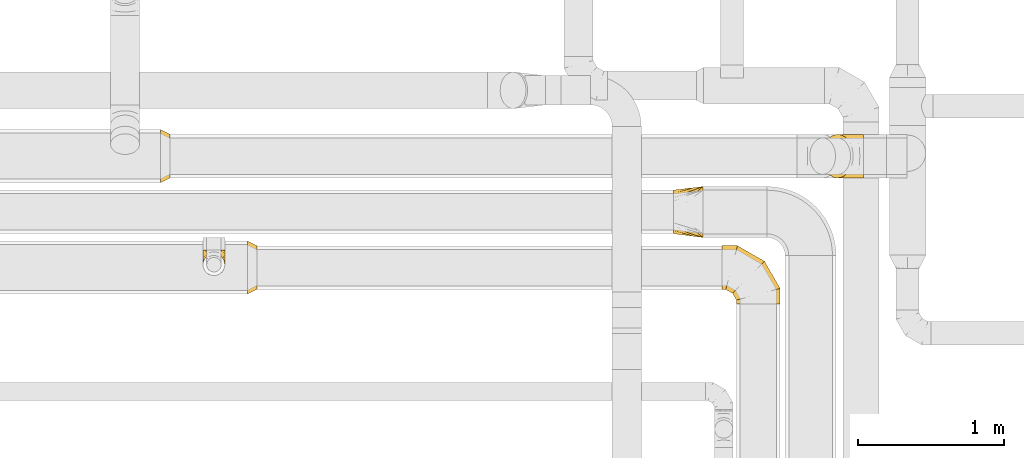
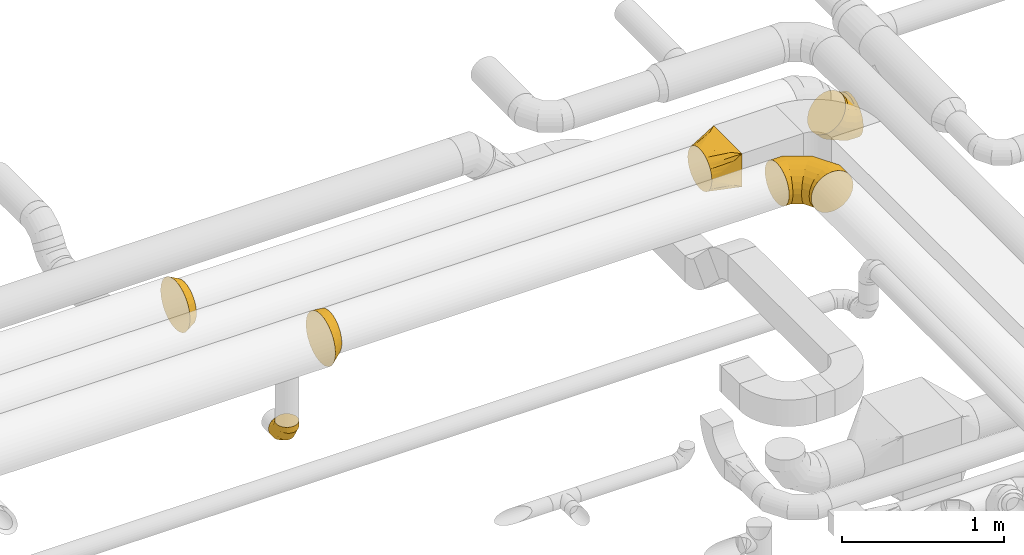
# One storey, part 25 of 92: 6 coverings.
"""IFC2X3 building model written with IfcOpenShell, lengths in millimetres."""

from ifc_helpers import new_model, entity, si_unit, converted_unit, derived_unit, direction, frame, origin, place, context, subcontext, project, spatial, faceted_brep, element, save


model = new_model("IFC2X3")

# Units and contexts
model_context = context("Model", 3, precision=0.01, world=origin(), true_north=direction((6.12303176911189e-17, 1.0)))
body_context = subcontext(model_context, "Body", "Model", "MODEL_VIEW")
ifc_project = project(units=[si_unit("LENGTHUNIT", "METRE", prefix="MILLI"), si_unit("AREAUNIT", "SQUARE_METRE"), si_unit("VOLUMEUNIT", "CUBIC_METRE"), converted_unit("PLANEANGLEUNIT", "DEGREE", entity("IfcRatioMeasure", 0.0174532925199433), si_unit("PLANEANGLEUNIT", "RADIAN"), dimensions=[0, 0, 0, 0, 0, 0, 0]), si_unit("MASSUNIT", "GRAM", prefix="KILO"), derived_unit("MASSDENSITYUNIT", [(si_unit("MASSUNIT", "GRAM", prefix="KILO"), 1), (si_unit("LENGTHUNIT", "METRE"), -3)]), derived_unit("MOMENTOFINERTIAUNIT", [(si_unit("LENGTHUNIT", "METRE"), 4)]), si_unit("TIMEUNIT", "SECOND"), si_unit("FREQUENCYUNIT", "HERTZ"), si_unit("THERMODYNAMICTEMPERATUREUNIT", "DEGREE_CELSIUS"), derived_unit("THERMALTRANSMITTANCEUNIT", [(si_unit("MASSUNIT", "GRAM", prefix="KILO"), 1), (si_unit("THERMODYNAMICTEMPERATUREUNIT", "KELVIN"), -1), (si_unit("TIMEUNIT", "SECOND"), -3)]), derived_unit("VOLUMETRICFLOWRATEUNIT", [(si_unit("LENGTHUNIT", "METRE"), 3), (si_unit("TIMEUNIT", "SECOND"), -1)]), derived_unit("MASSFLOWRATEUNIT", [(si_unit("MASSUNIT", "GRAM", prefix="KILO"), 1), (si_unit("TIMEUNIT", "SECOND"), -1)]), derived_unit("ROTATIONALFREQUENCYUNIT", [(si_unit("TIMEUNIT", "SECOND"), -1)]), si_unit("ELECTRICCURRENTUNIT", "AMPERE"), si_unit("ELECTRICVOLTAGEUNIT", "VOLT"), si_unit("POWERUNIT", "WATT"), si_unit("FORCEUNIT", "NEWTON", prefix="KILO"), si_unit("ILLUMINANCEUNIT", "LUX"), si_unit("LUMINOUSFLUXUNIT", "LUMEN"), si_unit("LUMINOUSINTENSITYUNIT", "CANDELA"), derived_unit("USERDEFINED", [(si_unit("MASSUNIT", "GRAM", prefix="KILO"), -1), (si_unit("LENGTHUNIT", "METRE"), -2), (si_unit("TIMEUNIT", "SECOND"), 3), (si_unit("LUMINOUSFLUXUNIT", "LUMEN"), 1)]), derived_unit("LINEARVELOCITYUNIT", [(si_unit("LENGTHUNIT", "METRE"), 1), (si_unit("TIMEUNIT", "SECOND"), -1)]), si_unit("PRESSUREUNIT", "PASCAL"), derived_unit("USERDEFINED", [(si_unit("LENGTHUNIT", "METRE"), -2), (si_unit("MASSUNIT", "GRAM", prefix="KILO"), 1), (si_unit("TIMEUNIT", "SECOND"), -2)]), derived_unit("LINEARFORCEUNIT", [(si_unit("MASSUNIT", "GRAM", prefix="KILO"), 1), (si_unit("LENGTHUNIT", "METRE"), 1), (si_unit("TIMEUNIT", "SECOND"), -2), (si_unit("LENGTHUNIT", "METRE"), -1)]), derived_unit("PLANARFORCEUNIT", [(si_unit("MASSUNIT", "GRAM", prefix="KILO"), 1), (si_unit("LENGTHUNIT", "METRE"), 1), (si_unit("TIMEUNIT", "SECOND"), -2), (si_unit("LENGTHUNIT", "METRE"), -2)])], contexts=[model_context])

# Site, building, storey
site_placement = place(None, origin())
site = spatial("IfcSite", under=ifc_project, at=site_placement, CompositionType="ELEMENT")
building_placement = place(site_placement, origin())
building = spatial("IfcBuilding", under=site, at=building_placement, CompositionType="ELEMENT")
storey_placement = place(building_placement, frame((0.0, 0.0, 4200.0)))
storey = spatial("IfcBuildingStorey", under=building, at=storey_placement, CompositionType="ELEMENT", Elevation=4200.0)

# Coverings
covering_1_placement = place(storey_placement, frame((60504.33, 15163.51, 3123.4)))
element("IfcCovering", 1, at=covering_1_placement, inside=storey, PredefinedType="INSULATION", context=body_context, shape_type="Brep", body=[
    faceted_brep([(0.0, 58.01, 242.13), (0.0, 69.93, 257.66), (0.0, 85.46, 269.58), (0.0, 100.99, 281.5), (0.0, 119.08, 288.99), (0.0, 137.17, 296.48), (0.0, 149.39, 298.09), (0.0, 161.61, 299.7), (0.0, 175.99, 301.6), (0.0, 190.37, 299.7), (0.0, 202.59, 298.09), (0.0, 214.81, 296.48), (0.0, 232.9, 288.99), (0.0, 250.99, 281.5), (0.0, 266.52, 269.58), (0.0, 282.06, 257.66), (0.0, 293.98, 242.13), (0.0, 305.89, 226.6), (0.0, 313.39, 208.51), (0.0, 320.88, 190.42), (0.0, 322.49, 178.2), (0.0, 324.1, 165.97), (0.0, 325.99, 151.6), (0.0, 324.1, 137.22), (0.0, 322.49, 124.99), (0.0, 320.88, 112.77), (0.0, 313.39, 94.68), (0.0, 305.89, 76.6), (0.0, 293.98, 61.06), (0.0, 282.06, 45.53), (0.0, 266.52, 33.61), (0.0, 250.99, 21.69), (0.0, 232.9, 14.2), (0.0, 214.81, 6.71), (0.0, 202.59, 5.1), (0.0, 190.37, 3.49), (0.0, 175.99, 1.6), (0.0, 161.61, 3.49), (0.0, 149.39, 5.1), (0.0, 137.17, 6.71), (0.0, 119.08, 14.2), (0.0, 100.99, 21.69), (0.0, 85.46, 33.61), (0.0, 69.93, 45.53), (0.0, 58.01, 61.06), (0.0, 46.09, 76.6), (0.0, 38.59, 94.68), (0.0, 31.1, 112.77), (0.0, 29.49, 124.99), (0.0, 27.88, 137.22), (0.0, 25.99, 151.6), (0.0, 27.88, 165.97), (0.0, 29.49, 178.2), (0.0, 31.1, 190.42), (0.0, 38.59, 208.51), (0.0, 46.09, 226.6), (200.0, 0.0, 301.6), (200.0, 0.0, 51.6), (200.0, 350.0, 51.6), (200.0, 350.0, 301.6), (71.91, 112.71, 19.57), (95.89, 91.62, 25.57), (121.91, 68.71, 32.07), (100.0, 38.27, 45.45), (173.97, 22.9, 45.09), (147.94, 6.77, 77.62), (173.97, 3.38, 64.61), (121.91, 10.15, 90.64), (95.89, 13.53, 103.65), (71.91, 16.65, 115.64), (23.97, 154.9, 7.59), (47.94, 133.8, 13.58), (47.94, 19.76, 127.62), (23.97, 22.88, 139.61), (147.94, 45.81, 38.58), (173.97, 3.38, 282.07), (147.94, 6.77, 262.55), (121.91, 10.15, 243.03), (95.89, 13.53, 223.51), (71.91, 16.65, 205.53), (47.94, 19.76, 187.55), (23.97, 22.88, 169.57), (100.0, 31.85, 276.32), (147.94, 45.81, 301.6), (173.97, 22.9, 301.6), (121.91, 68.71, 301.6), (95.89, 91.62, 301.6), (71.91, 112.71, 301.6), (47.94, 133.8, 301.6), (23.97, 154.9, 301.6), (173.97, 327.35, 301.6), (147.94, 304.71, 301.6), (121.91, 282.06, 301.6), (95.89, 259.42, 301.6), (71.91, 238.56, 301.6), (47.94, 217.7, 301.6), (23.97, 196.85, 301.6), (100.0, 312.72, 282.74), (147.94, 343.75, 262.55), (173.97, 346.88, 282.07), (121.91, 340.63, 243.03), (95.89, 337.5, 223.51), (71.91, 334.62, 205.53), (47.94, 331.75, 187.55), (23.97, 328.87, 169.57), (173.97, 346.88, 64.61), (147.94, 343.75, 77.62), (121.91, 340.63, 90.64), (95.89, 337.5, 103.65), (71.91, 334.62, 115.64), (47.94, 331.75, 127.62), (23.97, 328.87, 139.61), (100.0, 319.14, 51.87), (147.94, 304.71, 38.58), (173.97, 327.35, 45.09), (121.91, 282.06, 32.07), (95.89, 259.42, 25.57), (71.91, 238.56, 19.57), (47.94, 217.7, 13.58), (23.97, 196.85, 7.59)], [[[0, 1, 2, 3, 4, 5, 6, 7, 8, 9, 10, 11, 12, 13, 14, 15, 16, 17, 18, 19, 20, 21, 22, 23, 24, 25, 26, 27, 28, 29, 30, 31, 32, 33, 34, 35, 36, 37, 38, 39, 40, 41, 42, 43, 44, 45, 46, 47, 48, 49, 50, 51, 52, 53, 54, 55]], [[56, 57, 58, 59]], [[60, 61, 62, 40]], [[63, 42, 64]], [[44, 43, 63]], [[39, 60, 40]], [[40, 62, 41]], [[65, 45, 44]], [[44, 63, 66]], [[46, 67, 68, 69]], [[70, 71, 60, 39, 38, 37, 36]], [[48, 47, 69, 72, 73, 50, 49]], [[46, 45, 67]], [[46, 69, 47]], [[45, 65, 67]], [[42, 74, 64]], [[42, 41, 74]], [[57, 63, 64]], [[42, 63, 43]], [[44, 66, 65]], [[63, 57, 66]], [[62, 74, 41]], [[57, 56, 75, 76, 77, 78, 79, 80, 81, 50, 73, 72, 69, 68, 67, 65, 66]], [[79, 78, 77, 54]], [[82, 0, 75]], [[2, 1, 82]], [[53, 79, 54]], [[54, 77, 55]], [[83, 3, 2]], [[2, 82, 84]], [[4, 85, 86, 87]], [[81, 80, 79, 53, 52, 51, 50]], [[6, 5, 87, 88, 89, 8, 7]], [[4, 3, 85]], [[4, 87, 5]], [[3, 83, 85]], [[0, 76, 75]], [[0, 55, 76]], [[56, 82, 75]], [[0, 82, 1]], [[2, 84, 83]], [[82, 56, 84]], [[77, 76, 55]], [[89, 88, 87, 86, 85, 83, 84, 56, 59, 90, 91, 92, 93, 94, 95, 96, 8]], [[94, 93, 92, 12]], [[97, 14, 90]], [[16, 15, 97]], [[11, 94, 12]], [[12, 92, 13]], [[98, 17, 16]], [[16, 97, 99]], [[18, 100, 101, 102]], [[96, 95, 94, 11, 10, 9, 8]], [[20, 19, 102, 103, 104, 22, 21]], [[18, 17, 100]], [[18, 102, 19]], [[17, 98, 100]], [[14, 91, 90]], [[14, 13, 91]], [[59, 97, 90]], [[14, 97, 15]], [[16, 99, 98]], [[97, 59, 99]], [[92, 91, 13]], [[104, 103, 102, 101, 100, 98, 99, 59, 58, 105, 106, 107, 108, 109, 110, 111, 22]], [[109, 108, 107, 26]], [[112, 28, 105]], [[30, 29, 112]], [[25, 109, 26]], [[26, 107, 27]], [[113, 31, 30]], [[30, 112, 114]], [[32, 115, 116, 117]], [[111, 110, 109, 25, 24, 23, 22]], [[34, 33, 117, 118, 119, 36, 35]], [[32, 31, 115]], [[32, 117, 33]], [[31, 113, 115]], [[28, 106, 105]], [[28, 27, 106]], [[58, 112, 105]], [[28, 112, 29]], [[30, 114, 113]], [[112, 58, 114]], [[107, 106, 27]], [[58, 57, 64, 74, 62, 61, 60, 71, 70, 36, 119, 118, 117, 116, 115, 113, 114]]]),
])
covering_2_placement = place(storey_placement, frame((61522.45, 15570.41, 2848.4)))
element("IfcCovering", 2, at=covering_2_placement, inside=storey, PredefinedType="INSULATION", context=body_context, shape_type="Brep", body=[
    faceted_brep([(284.44, 151.6, 301.6), (284.44, 112.77, 296.48), (284.44, 76.6, 281.5), (284.44, 45.53, 257.66), (284.44, 21.69, 226.6), (284.44, 6.71, 190.42), (284.44, 1.6, 151.6), (284.44, 6.71, 112.77), (284.44, 21.69, 76.6), (284.44, 45.53, 45.53), (284.44, 76.6, 21.69), (284.44, 112.77, 6.71), (284.44, 151.6, 1.6), (284.44, 190.42, 6.71), (284.44, 226.6, 21.69), (284.44, 257.66, 45.53), (284.44, 281.5, 76.6), (284.44, 296.48, 112.77), (284.44, 301.6, 151.6), (284.44, 296.48, 190.42), (284.44, 281.5, 226.6), (284.44, 257.66, 257.66), (284.44, 226.6, 281.5), (284.44, 190.42, 296.48), (15.81, 226.6, 132.96), (5.21, 190.42, 122.37), (1.6, 151.6, 118.75), (5.21, 112.77, 122.37), (15.81, 76.6, 132.96), (32.66, 45.53, 149.82), (54.63, 21.69, 171.79), (80.21, 6.71, 197.37), (107.66, 1.6, 224.82), (135.11, 6.71, 252.27), (160.69, 21.69, 277.85), (182.66, 45.53, 299.82), (199.52, 76.6, 316.67), (210.11, 112.77, 327.27), (213.73, 151.6, 330.88), (210.11, 190.42, 327.27), (199.52, 226.6, 316.67), (182.66, 257.66, 299.82), (160.69, 281.5, 277.85), (135.11, 296.48, 252.27), (107.66, 301.6, 224.82), (80.21, 296.48, 197.37), (54.63, 281.5, 171.79), (32.66, 257.66, 149.82), (57.86, 151.6, 62.49), (60.75, 112.77, 66.82), (69.24, 76.6, 79.53), (82.74, 45.53, 99.74), (100.34, 21.69, 126.07), (120.83, 6.71, 156.74), (142.82, 1.6, 189.66), (164.82, 6.71, 222.57), (185.31, 21.69, 253.24), (202.91, 45.53, 279.57), (216.41, 76.6, 299.78), (224.9, 112.77, 312.49), (227.79, 151.6, 316.82), (224.9, 190.42, 312.49), (216.41, 226.6, 299.78), (202.91, 257.66, 279.57), (164.82, 296.48, 222.57), (142.82, 301.6, 189.66), (185.31, 281.5, 253.24), (120.83, 296.48, 156.74), (100.34, 281.5, 126.07), (82.74, 257.66, 99.74), (69.24, 226.6, 79.53), (60.75, 190.42, 66.82), (204.87, 151.6, 1.6), (205.89, 112.77, 6.71), (208.87, 76.6, 21.69), (213.61, 45.53, 45.53), (219.79, 21.69, 76.6), (226.99, 6.71, 112.77), (234.71, 1.6, 151.6), (242.43, 6.71, 190.42), (249.63, 21.69, 226.6), (255.81, 45.53, 257.66), (260.55, 76.6, 281.5), (263.53, 112.77, 296.48), (264.55, 151.6, 301.6), (263.53, 190.42, 296.48), (260.55, 226.6, 281.5), (255.81, 257.66, 257.66), (242.43, 296.48, 190.42), (234.71, 301.6, 151.6), (249.63, 281.5, 226.6), (226.99, 296.48, 112.77), (219.79, 281.5, 76.6), (213.61, 257.66, 45.53), (208.87, 226.6, 21.69), (205.89, 190.42, 6.71)], [[[0, 1, 2, 3, 4, 5, 6, 7, 8, 9, 10, 11, 12, 13, 14, 15, 16, 17, 18, 19, 20, 21, 22, 23]], [[24, 25, 26, 27, 28, 29, 30, 31, 32, 33, 34, 35, 36, 37, 38, 39, 40, 41, 42, 43, 44, 45, 46, 47]], [[26, 48, 49, 27]], [[27, 49, 50, 28]], [[51, 29, 28, 50]], [[29, 51, 52, 30]], [[30, 52, 53, 31]], [[54, 32, 31, 53]], [[55, 56, 34, 33]], [[54, 55, 33, 32]], [[57, 35, 34, 56]], [[58, 59, 37, 36]], [[58, 36, 35, 57]], [[60, 38, 37, 59]], [[61, 62, 40, 39]], [[60, 61, 39, 38]], [[41, 40, 62, 63]], [[64, 65, 44, 43]], [[66, 64, 43, 42]], [[63, 66, 42, 41]], [[45, 44, 65, 67]], [[46, 45, 67, 68]], [[47, 46, 68, 69]], [[25, 24, 70, 71]], [[26, 25, 71, 48]], [[69, 70, 24, 47]], [[49, 48, 72, 73]], [[50, 49, 73, 74]], [[74, 75, 51, 50]], [[52, 51, 75, 76]], [[53, 52, 76, 77]], [[54, 53, 77, 78]], [[79, 80, 56, 55]], [[78, 79, 55, 54]], [[57, 56, 80, 81]], [[82, 83, 59, 58]], [[81, 82, 58, 57]], [[60, 59, 83, 84]], [[85, 86, 62, 61]], [[84, 85, 61, 60]], [[63, 62, 86, 87]], [[88, 89, 65, 64]], [[90, 88, 64, 66]], [[87, 90, 66, 63]], [[67, 65, 89, 91]], [[68, 67, 91, 92]], [[69, 68, 92, 93]], [[71, 70, 94, 95]], [[48, 71, 95, 72]], [[93, 94, 70, 69]], [[73, 72, 12, 11]], [[74, 73, 11, 10]], [[10, 9, 75, 74]], [[77, 76, 8, 7]], [[78, 77, 7, 6]], [[9, 8, 76, 75]], [[79, 78, 6, 5]], [[80, 79, 5, 4]], [[81, 80, 4, 3]], [[83, 82, 2, 1]], [[84, 83, 1, 0]], [[81, 3, 2, 82]], [[84, 0, 23, 85]], [[85, 23, 22, 86]], [[86, 22, 21, 87]], [[90, 20, 19, 88]], [[88, 19, 18, 89]], [[90, 87, 21, 20]], [[17, 16, 92, 91]], [[18, 17, 91, 89]], [[15, 93, 92, 16]], [[94, 14, 13, 95]], [[95, 13, 12, 72]], [[14, 94, 93, 15]]]),
])
covering_3_placement = place(storey_placement, frame((56980.65, 15537.91, 3065.9)))
element("IfcCovering", 3, at=covering_3_placement, inside=storey, PredefinedType="INSULATION", context=body_context, shape_type="Brep", body=[
    faceted_brep([(0.0, 275.35, 342.14), (0.0, 313.14, 313.14), (0.0, 342.14, 275.35), (0.0, 360.38, 231.33), (0.0, 366.6, 184.1), (0.0, 360.38, 136.86), (0.0, 342.14, 92.85), (0.0, 313.14, 55.05), (0.0, 275.35, 26.05), (0.0, 231.33, 7.81), (0.0, 184.1, 1.6), (0.0, 136.86, 7.81), (0.0, 92.85, 26.05), (0.0, 55.05, 55.05), (0.0, 26.05, 92.85), (0.0, 7.81, 136.86), (0.0, 1.6, 184.1), (0.0, 7.81, 231.33), (0.0, 26.05, 275.35), (0.0, 55.05, 313.14), (0.0, 92.85, 342.14), (0.0, 136.86, 360.38), (0.0, 184.1, 366.6), (0.0, 231.33, 360.38), (65.0, 222.92, 328.98), (65.0, 184.1, 334.1), (65.0, 145.27, 328.98), (65.0, 109.1, 314.0), (65.0, 78.03, 290.16), (65.0, 54.19, 259.1), (65.0, 39.21, 222.92), (65.0, 34.1, 184.1), (65.0, 39.21, 145.27), (65.0, 54.19, 109.1), (65.0, 78.03, 78.03), (65.0, 109.1, 54.19), (65.0, 145.27, 39.21), (65.0, 184.1, 34.1), (65.0, 222.92, 39.21), (65.0, 259.1, 54.19), (65.0, 290.16, 78.03), (65.0, 314.0, 109.1), (65.0, 328.98, 145.27), (65.0, 334.1, 184.1), (65.0, 328.98, 222.92), (65.0, 314.0, 259.1), (65.0, 290.16, 290.16), (65.0, 259.1, 314.0)], [[[0, 1, 2, 3, 4, 5, 6, 7, 8, 9, 10, 11, 12, 13, 14, 15, 16, 17, 18, 19, 20, 21, 22, 23]], [[24, 25, 26, 27, 28, 29, 30, 31, 32, 33, 34, 35, 36, 37, 38, 39, 40, 41, 42, 43, 44, 45, 46, 47]], [[42, 41, 6, 5]], [[43, 42, 5, 4]], [[7, 6, 41, 40]], [[7, 40, 39, 8]], [[8, 39, 38, 9]], [[37, 10, 9, 38]], [[36, 35, 12, 11]], [[37, 36, 11, 10]], [[13, 12, 35, 34]], [[13, 34, 33, 14]], [[14, 33, 32, 15]], [[31, 16, 15, 32]], [[30, 29, 18, 17]], [[31, 30, 17, 16]], [[19, 18, 29, 28]], [[19, 28, 27, 20]], [[20, 27, 26, 21]], [[25, 22, 21, 26]], [[24, 47, 0, 23]], [[25, 24, 23, 22]], [[1, 0, 47, 46]], [[1, 46, 45, 2]], [[2, 45, 44, 3]], [[43, 4, 3, 44]]]),
])
covering_4_placement = place(storey_placement, frame((57270.37, 14900.4, 2523.4)))
element("IfcCovering", 4, at=covering_4_placement, inside=storey, PredefinedType="INSULATION", context=body_context, shape_type="Brep", body=[
    faceted_brep([(105.3, 176.6, 7.3), (90.95, 176.6, 4.45), (76.6, 176.6, 1.6), (62.24, 176.6, 4.45), (47.89, 176.6, 7.3), (35.73, 176.6, 15.43), (23.56, 176.6, 23.56), (15.43, 176.6, 35.73), (7.3, 176.6, 47.89), (4.45, 176.6, 62.24), (1.6, 176.6, 76.6), (4.45, 176.6, 90.95), (7.3, 176.6, 105.3), (15.43, 176.6, 117.46), (23.56, 176.6, 129.63), (35.73, 176.6, 137.76), (47.89, 176.6, 145.89), (62.24, 176.6, 148.74), (69.42, 176.6, 150.17), (76.6, 176.6, 151.6), (83.77, 176.6, 150.17), (90.95, 176.6, 148.74), (105.3, 176.6, 145.89), (117.46, 176.6, 137.76), (129.63, 176.6, 129.63), (137.76, 176.6, 117.46), (145.89, 176.6, 105.3), (148.74, 176.6, 90.95), (151.6, 176.6, 76.6), (148.74, 176.6, 62.24), (145.89, 176.6, 47.89), (137.76, 176.6, 35.73), (129.63, 176.6, 23.56), (117.46, 176.6, 15.43), (57.18, 4.15, 176.6), (76.6, 1.6, 176.6), (96.01, 4.15, 176.6), (114.1, 11.64, 176.6), (129.63, 23.56, 176.6), (141.55, 39.1, 176.6), (149.04, 57.18, 176.6), (151.6, 76.6, 176.6), (149.04, 96.01, 176.6), (141.55, 114.1, 176.6), (129.63, 129.63, 176.6), (114.1, 141.55, 176.6), (96.01, 149.04, 176.6), (76.6, 151.6, 176.6), (57.18, 149.04, 176.6), (39.1, 141.55, 176.6), (23.56, 129.63, 176.6), (11.64, 114.1, 176.6), (4.15, 96.01, 176.6), (1.6, 76.6, 176.6), (4.15, 57.18, 176.6), (11.64, 39.1, 176.6), (23.56, 23.56, 176.6), (39.1, 11.64, 176.6), (76.6, 1.6, 129.7), (96.01, 4.15, 130.39), (114.1, 11.64, 132.4), (129.63, 23.56, 135.59), (141.55, 39.1, 139.75), (149.04, 57.18, 144.6), (151.6, 76.6, 149.8), (149.04, 96.01, 155.0), (141.55, 114.1, 159.85), (129.63, 129.63, 164.01), (114.1, 141.55, 167.2), (96.01, 149.04, 169.21), (76.6, 151.6, 169.9), (57.18, 149.04, 169.21), (39.1, 141.55, 167.2), (23.56, 129.63, 164.01), (4.15, 96.01, 155.0), (1.6, 76.6, 149.8), (11.64, 114.1, 159.85), (4.15, 57.18, 144.6), (11.64, 39.1, 139.75), (23.56, 23.56, 135.59), (39.1, 11.64, 132.4), (57.18, 4.15, 130.39), (76.6, 48.49, 48.49), (96.01, 50.36, 50.36), (114.1, 55.84, 55.84), (129.63, 64.57, 64.57), (141.55, 75.94, 75.94), (149.04, 89.18, 89.18), (151.6, 103.39, 103.39), (149.04, 117.6, 117.6), (141.55, 130.84, 130.84), (129.63, 142.21, 142.21), (114.1, 150.94, 150.94), (96.01, 156.42, 156.42), (76.6, 158.29, 158.29), (57.18, 156.42, 156.42), (39.1, 150.94, 150.94), (23.56, 142.21, 142.21), (4.15, 117.6, 117.6), (1.6, 103.39, 103.39), (11.64, 130.84, 130.84), (4.15, 89.18, 89.18), (11.64, 75.94, 75.94), (23.56, 64.57, 64.57), (39.1, 55.84, 55.84), (57.18, 50.36, 50.36), (76.6, 129.7, 1.6), (96.01, 130.39, 4.15), (114.1, 132.4, 11.64), (129.63, 135.59, 23.56), (141.55, 139.75, 39.1), (149.04, 144.6, 57.18), (151.6, 149.8, 76.6), (149.04, 155.0, 96.01), (141.55, 159.85, 114.1), (129.63, 164.01, 129.63), (114.1, 167.2, 141.55), (105.05, 168.21, 145.29), (96.01, 169.21, 149.04), (86.3, 169.55, 150.32), (76.6, 169.9, 151.6), (57.18, 169.21, 149.04), (48.14, 168.21, 145.29), (39.1, 167.2, 141.55), (66.89, 169.55, 150.32), (23.56, 164.01, 129.63), (4.15, 155.0, 96.01), (1.6, 149.8, 76.6), (11.64, 159.85, 114.1), (4.15, 144.6, 57.18), (11.64, 139.75, 39.1), (23.56, 135.59, 23.56), (39.1, 132.4, 11.64), (57.18, 130.39, 4.15)], [[[0, 1, 2, 3, 4, 5, 6, 7, 8, 9, 10, 11, 12, 13, 14, 15, 16, 17, 18, 19, 20, 21, 22, 23, 24, 25, 26, 27, 28, 29, 30, 31, 32, 33]], [[34, 35, 36, 37, 38, 39, 40, 41, 42, 43, 44, 45, 46, 47, 48, 49, 50, 51, 52, 53, 54, 55, 56, 57]], [[35, 58, 59, 36]], [[36, 59, 60, 37]], [[37, 60, 61, 38]], [[39, 62, 63, 40]], [[40, 63, 64, 41]], [[38, 61, 62, 39]], [[65, 66, 43, 42]], [[64, 65, 42, 41]], [[67, 44, 43, 66]], [[68, 69, 46, 45]], [[68, 45, 44, 67]], [[70, 47, 46, 69]], [[71, 72, 49, 48]], [[70, 71, 48, 47]], [[50, 49, 72, 73]], [[74, 75, 53, 52]], [[76, 74, 52, 51]], [[73, 76, 51, 50]], [[55, 54, 77, 78]], [[56, 55, 78, 79]], [[53, 75, 77, 54]], [[34, 57, 80, 81]], [[35, 34, 81, 58]], [[79, 80, 57, 56]], [[58, 82, 83, 59]], [[60, 59, 83, 84]], [[84, 85, 61, 60]], [[62, 61, 85, 86]], [[63, 62, 86, 87]], [[64, 63, 87, 88]], [[89, 90, 66, 65]], [[88, 89, 65, 64]], [[67, 66, 90, 91]], [[92, 93, 69, 68]], [[91, 92, 68, 67]], [[70, 69, 93, 94]], [[95, 96, 72, 71]], [[94, 95, 71, 70]], [[73, 72, 96, 97]], [[98, 99, 75, 74]], [[100, 98, 74, 76]], [[97, 100, 76, 73]], [[77, 75, 99, 101]], [[78, 77, 101, 102]], [[79, 78, 102, 103]], [[81, 80, 104, 105]], [[58, 81, 105, 82]], [[103, 104, 80, 79]], [[82, 106, 107, 83]], [[84, 83, 107, 108]], [[108, 109, 85, 84]], [[86, 85, 109, 110]], [[87, 86, 110, 111]], [[88, 87, 111, 112]], [[113, 114, 90, 89]], [[112, 113, 89, 88]], [[91, 90, 114, 115]], [[93, 92, 116, 117, 118]], [[115, 116, 92, 91]], [[94, 93, 118, 119, 120]], [[95, 121, 122, 123, 96]], [[94, 120, 124, 121, 95]], [[97, 96, 123, 125]], [[126, 127, 99, 98]], [[128, 126, 98, 100]], [[125, 128, 100, 97]], [[101, 99, 127, 129]], [[102, 101, 129, 130]], [[103, 102, 130, 131]], [[105, 104, 132, 133]], [[82, 105, 133, 106]], [[131, 132, 104, 103]], [[106, 1, 107]], [[111, 30, 29]], [[1, 106, 2]], [[32, 109, 33]], [[108, 0, 33]], [[107, 0, 108]], [[31, 30, 110]], [[108, 33, 109]], [[31, 109, 32]], [[28, 112, 29]], [[1, 0, 107]], [[112, 111, 29]], [[110, 30, 111]], [[109, 31, 110]], [[113, 28, 27, 26]], [[24, 115, 25]], [[119, 21, 20]], [[114, 26, 25]], [[114, 113, 26]], [[120, 20, 19]], [[114, 25, 115]], [[28, 113, 112]], [[120, 119, 20]], [[21, 119, 118]], [[22, 118, 117, 116]], [[24, 23, 115]], [[115, 23, 116]], [[118, 22, 21]], [[116, 23, 22]], [[121, 17, 16]], [[15, 14, 125]], [[16, 123, 122, 121]], [[18, 17, 124]], [[18, 120, 19]], [[125, 123, 15]], [[13, 125, 14]], [[126, 12, 11, 10]], [[125, 13, 128]], [[120, 18, 124]], [[126, 128, 12]], [[126, 10, 127]], [[17, 121, 124]], [[123, 16, 15]], [[13, 12, 128]], [[127, 9, 129]], [[6, 131, 7]], [[130, 8, 7]], [[129, 8, 130]], [[5, 131, 6]], [[9, 8, 129]], [[130, 7, 131]], [[9, 127, 10]], [[133, 4, 3]], [[131, 5, 132]], [[2, 106, 3]], [[4, 133, 132]], [[106, 133, 3]], [[5, 4, 132]]]),
])
covering_5_placement = place(storey_placement, frame((60835.0, 14707.0, 3130.9)))
element("IfcCovering", 5, at=covering_5_placement, inside=storey, PredefinedType="INSULATION", context=body_context, shape_type="Brep", body=[
    faceted_brep([(0.0, 356.07, 257.66), (0.0, 379.9, 226.6), (0.0, 394.89, 190.42), (0.0, 400.0, 151.6), (0.0, 394.89, 112.77), (0.0, 379.9, 76.6), (0.0, 356.07, 45.53), (0.0, 325.0, 21.69), (0.0, 288.82, 6.71), (0.0, 250.0, 1.6), (0.0, 211.18, 6.71), (0.0, 175.0, 21.69), (0.0, 143.93, 45.53), (0.0, 120.1, 76.6), (0.0, 105.11, 112.77), (0.0, 100.0, 151.6), (0.0, 105.11, 190.42), (0.0, 120.1, 226.6), (0.0, 143.93, 257.66), (0.0, 175.0, 281.5), (0.0, 211.18, 296.48), (0.0, 250.0, 301.6), (0.0, 288.82, 296.48), (0.0, 325.0, 281.5), (379.9, 0.0, 76.6), (394.89, 0.0, 112.77), (400.0, 0.0, 151.6), (394.89, 0.0, 190.42), (379.9, 0.0, 226.6), (356.07, 0.0, 257.66), (325.0, 0.0, 281.5), (288.82, 0.0, 296.48), (250.0, 0.0, 301.6), (211.18, 0.0, 296.48), (175.0, 0.0, 281.5), (143.93, 0.0, 257.66), (120.1, 0.0, 226.6), (105.11, 0.0, 190.42), (100.0, 0.0, 151.6), (105.11, 0.0, 112.77), (120.1, 0.0, 76.6), (143.93, 0.0, 45.53), (175.0, 0.0, 21.69), (211.18, 0.0, 6.71), (250.0, 0.0, 1.6), (288.82, 0.0, 6.71), (325.0, 0.0, 21.69), (356.07, 0.0, 45.53), (400.0, 107.18, 151.6), (394.89, 105.81, 190.42), (379.9, 101.79, 226.6), (356.07, 95.41, 257.66), (325.0, 87.08, 281.5), (288.82, 77.39, 296.48), (250.0, 66.99, 301.6), (211.18, 56.58, 296.48), (175.0, 46.89, 281.5), (143.93, 38.57, 257.66), (120.1, 32.18, 226.6), (105.11, 28.16, 190.42), (100.0, 26.79, 151.6), (105.11, 28.16, 112.77), (120.1, 32.18, 76.6), (143.93, 38.57, 45.53), (211.18, 56.58, 6.71), (250.0, 66.99, 1.6), (175.0, 46.89, 21.69), (288.82, 77.39, 6.71), (325.0, 87.08, 21.69), (356.07, 95.41, 45.53), (379.9, 101.79, 76.6), (394.89, 105.81, 112.77), (292.82, 292.82, 151.6), (289.08, 289.08, 190.42), (278.11, 278.11, 226.6), (260.66, 260.66, 257.66), (237.92, 237.92, 281.5), (211.43, 211.43, 296.48), (183.01, 183.01, 301.6), (154.59, 154.59, 296.48), (128.11, 128.11, 281.5), (105.37, 105.37, 257.66), (87.92, 87.92, 226.6), (76.95, 76.95, 190.42), (73.21, 73.21, 151.6), (76.95, 76.95, 112.77), (87.92, 87.92, 76.6), (105.37, 105.37, 45.53), (154.59, 154.59, 6.71), (183.01, 183.01, 1.6), (128.11, 128.11, 21.69), (211.43, 211.43, 6.71), (237.92, 237.92, 21.69), (260.66, 260.66, 45.53), (278.11, 278.11, 76.6), (289.08, 289.08, 112.77), (107.18, 400.0, 151.6), (105.81, 394.89, 190.42), (101.79, 379.9, 226.6), (95.41, 356.07, 257.66), (87.08, 325.0, 281.5), (77.39, 288.82, 296.48), (66.99, 250.0, 301.6), (56.58, 211.18, 296.48), (46.89, 175.0, 281.5), (38.57, 143.93, 257.66), (32.18, 120.1, 226.6), (28.16, 105.11, 190.42), (26.79, 100.0, 151.6), (28.16, 105.11, 112.77), (32.18, 120.1, 76.6), (38.57, 143.93, 45.53), (56.58, 211.18, 6.71), (66.99, 250.0, 1.6), (46.89, 175.0, 21.69), (77.39, 288.82, 6.71), (87.08, 325.0, 21.69), (95.41, 356.07, 45.53), (101.79, 379.9, 76.6), (105.81, 394.89, 112.77)], [[[0, 1, 2, 3, 4, 5, 6, 7, 8, 9, 10, 11, 12, 13, 14, 15, 16, 17, 18, 19, 20, 21, 22, 23]], [[24, 25, 26, 27, 28, 29, 30, 31, 32, 33, 34, 35, 36, 37, 38, 39, 40, 41, 42, 43, 44, 45, 46, 47]], [[26, 48, 49, 27]], [[27, 49, 50, 28]], [[51, 29, 28, 50]], [[29, 51, 52, 30]], [[30, 52, 53, 31]], [[54, 32, 31, 53]], [[55, 56, 34, 33]], [[54, 55, 33, 32]], [[57, 35, 34, 56]], [[58, 59, 37, 36]], [[58, 36, 35, 57]], [[60, 38, 37, 59]], [[61, 62, 40, 39]], [[60, 61, 39, 38]], [[41, 40, 62, 63]], [[64, 65, 44, 43]], [[66, 64, 43, 42]], [[63, 66, 42, 41]], [[45, 44, 65, 67]], [[46, 45, 67, 68]], [[68, 69, 47, 46]], [[25, 24, 70, 71]], [[26, 25, 71, 48]], [[69, 70, 24, 47]], [[49, 48, 72, 73]], [[50, 49, 73, 74]], [[74, 75, 51, 50]], [[52, 51, 75, 76]], [[53, 52, 76, 77]], [[54, 53, 77, 78]], [[79, 80, 56, 55]], [[78, 79, 55, 54]], [[57, 56, 80, 81]], [[82, 83, 59, 58]], [[81, 82, 58, 57]], [[60, 59, 83, 84]], [[85, 86, 62, 61]], [[84, 85, 61, 60]], [[63, 62, 86, 87]], [[88, 89, 65, 64]], [[90, 88, 64, 66]], [[87, 90, 66, 63]], [[67, 65, 89, 91]], [[68, 67, 91, 92]], [[69, 68, 92, 93]], [[71, 70, 94, 95]], [[48, 71, 95, 72]], [[93, 94, 70, 69]], [[73, 72, 96, 97]], [[74, 73, 97, 98]], [[98, 99, 75, 74]], [[76, 75, 99, 100]], [[77, 76, 100, 101]], [[78, 77, 101, 102]], [[103, 104, 80, 79]], [[102, 103, 79, 78]], [[81, 80, 104, 105]], [[106, 107, 83, 82]], [[105, 106, 82, 81]], [[84, 83, 107, 108]], [[109, 110, 86, 85]], [[108, 109, 85, 84]], [[87, 86, 110, 111]], [[112, 113, 89, 88]], [[114, 112, 88, 90]], [[111, 114, 90, 87]], [[91, 89, 113, 115]], [[92, 91, 115, 116]], [[93, 92, 116, 117]], [[95, 94, 118, 119]], [[72, 95, 119, 96]], [[117, 118, 94, 93]], [[97, 96, 3, 2]], [[98, 97, 2, 1]], [[1, 0, 99, 98]], [[101, 100, 23, 22]], [[102, 101, 22, 21]], [[0, 23, 100, 99]], [[103, 102, 21, 20]], [[104, 103, 20, 19]], [[105, 104, 19, 18]], [[107, 106, 17, 16]], [[108, 107, 16, 15]], [[105, 18, 17, 106]], [[108, 15, 14, 109]], [[109, 14, 13, 110]], [[110, 13, 12, 111]], [[10, 9, 113, 112]], [[11, 10, 112, 114]], [[114, 111, 12, 11]], [[113, 9, 8, 115]], [[115, 8, 7, 116]], [[6, 117, 116, 7]], [[118, 5, 4, 119]], [[119, 4, 3, 96]], [[5, 118, 117, 6]]]),
])
covering_6_placement = place(storey_placement, frame((57576.62, 14772.9, 3065.9)))
element("IfcCovering", 6, at=covering_6_placement, inside=storey, PredefinedType="INSULATION", context=body_context, shape_type="Brep", body=[
    faceted_brep([(0.0, 231.33, 360.38), (0.0, 275.35, 342.14), (0.0, 313.14, 313.14), (0.0, 342.14, 275.35), (0.0, 360.38, 231.33), (0.0, 366.6, 184.1), (0.0, 360.38, 136.86), (0.0, 342.14, 92.85), (0.0, 313.14, 55.05), (0.0, 275.35, 26.05), (0.0, 231.33, 7.81), (0.0, 184.1, 1.6), (0.0, 136.86, 7.81), (0.0, 92.85, 26.05), (0.0, 55.05, 55.05), (0.0, 26.05, 92.85), (0.0, 7.81, 136.86), (0.0, 1.6, 184.1), (0.0, 7.81, 231.33), (0.0, 26.05, 275.35), (0.0, 55.05, 313.14), (0.0, 92.85, 342.14), (0.0, 136.86, 360.38), (0.0, 184.1, 366.6), (65.0, 184.1, 366.6), (65.0, 145.27, 361.48), (65.0, 109.1, 346.5), (65.0, 78.03, 322.66), (65.0, 54.19, 291.6), (65.0, 39.21, 255.42), (65.0, 34.1, 216.6), (65.0, 39.21, 177.77), (65.0, 54.19, 141.6), (65.0, 78.03, 110.53), (65.0, 109.1, 86.69), (65.0, 145.27, 71.71), (65.0, 184.1, 66.6), (65.0, 222.92, 71.71), (65.0, 259.1, 86.69), (65.0, 290.16, 110.53), (65.0, 314.0, 141.6), (65.0, 328.98, 177.77), (65.0, 334.1, 216.6), (65.0, 328.98, 255.42), (65.0, 314.0, 291.6), (65.0, 290.16, 322.66), (65.0, 259.1, 346.5), (65.0, 222.92, 361.48), (32.5, 337.69, 136.72), (32.5, 315.99, 99.14), (31.23, 347.82, 167.39), (33.52, 349.83, 200.86), (37.09, 348.05, 202.64), (31.23, 216.41, 35.98), (32.5, 285.3, 68.45), (32.5, 247.72, 46.75), (37.09, 184.1, 38.68), (32.5, 120.47, 46.75), (32.5, 82.89, 68.45), (31.23, 151.78, 35.98), (31.23, 20.37, 167.39), (32.5, 52.2, 99.14), (32.5, 30.5, 136.72), (37.09, 20.14, 202.64), (33.52, 18.36, 200.86), (32.5, 30.5, 263.97), (32.5, 52.2, 301.55), (33.95, 21.75, 233.38), (31.08, 151.55, 363.39), (32.5, 82.89, 332.24), (32.5, 120.47, 353.94), (33.52, 184.1, 366.6), (32.5, 247.72, 353.94), (32.5, 285.3, 332.24), (33.95, 216.4, 363.41), (31.08, 347.85, 232.18), (32.5, 315.99, 301.55), (32.5, 337.69, 263.97)], [[[0, 1, 2, 3, 4, 5, 6, 7, 8, 9, 10, 11, 12, 13, 14, 15, 16, 17, 18, 19, 20, 21, 22, 23]], [[24, 25, 26, 27, 28, 29, 30, 31, 32, 33, 34, 35, 36, 37, 38, 39, 40, 41, 42, 43, 44, 45, 46, 47]], [[48, 40, 49]], [[48, 6, 50]], [[41, 40, 48]], [[41, 48, 50]], [[50, 5, 51, 52, 42]], [[48, 49, 7]], [[42, 41, 50]], [[6, 48, 7]], [[49, 8, 7]], [[36, 53, 37]], [[54, 49, 39]], [[53, 10, 55]], [[55, 38, 37]], [[9, 55, 10]], [[37, 53, 55]], [[11, 10, 53]], [[54, 9, 8]], [[55, 54, 38]], [[5, 50, 6]], [[55, 9, 54]], [[49, 54, 8]], [[38, 54, 39]], [[39, 49, 40]], [[11, 53, 36, 56]], [[57, 34, 58]], [[57, 12, 59]], [[35, 34, 57]], [[35, 57, 59]], [[56, 36, 59, 11]], [[57, 58, 13]], [[36, 35, 59]], [[12, 57, 13]], [[58, 14, 13]], [[30, 60, 31]], [[61, 58, 33]], [[60, 16, 62]], [[62, 32, 31]], [[15, 62, 16]], [[31, 60, 62]], [[17, 16, 60]], [[61, 15, 14]], [[62, 61, 32]], [[11, 59, 12]], [[62, 15, 61]], [[58, 61, 14]], [[32, 61, 33]], [[33, 58, 34]], [[60, 30, 63, 64, 17]], [[65, 28, 66]], [[17, 67, 18]], [[29, 28, 65]], [[67, 29, 65]], [[64, 63, 30, 67, 17]], [[65, 66, 19]], [[30, 29, 67]], [[20, 19, 66]], [[65, 19, 18]], [[24, 68, 25]], [[69, 66, 27]], [[26, 69, 27]], [[70, 26, 25]], [[21, 70, 22]], [[24, 71, 23, 68]], [[23, 22, 68]], [[69, 21, 20]], [[70, 69, 26]], [[70, 21, 69]], [[66, 69, 20]], [[68, 22, 70]], [[25, 68, 70]], [[27, 66, 28]], [[18, 67, 65]], [[72, 46, 73]], [[23, 74, 0]], [[47, 46, 72]], [[74, 47, 72]], [[71, 24, 74, 23]], [[72, 73, 1]], [[24, 47, 74]], [[2, 1, 73]], [[72, 1, 0]], [[42, 75, 43]], [[76, 73, 45]], [[44, 76, 45]], [[77, 44, 43]], [[3, 77, 4]], [[75, 42, 52, 51, 5]], [[5, 4, 75]], [[76, 3, 2]], [[77, 76, 44]], [[77, 3, 76]], [[73, 76, 2]], [[75, 4, 77]], [[43, 75, 77]], [[45, 73, 46]], [[0, 74, 72]]]),
])

save(model, "model.ifc")
